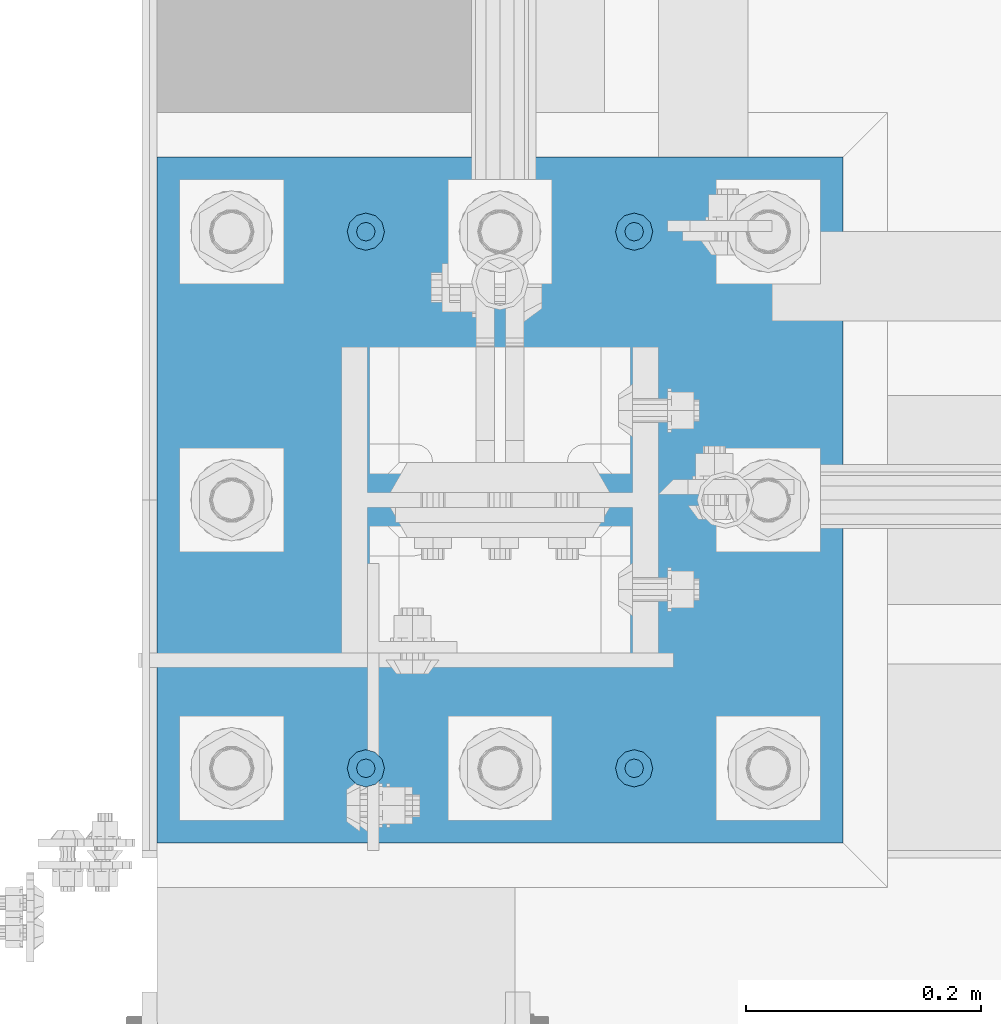
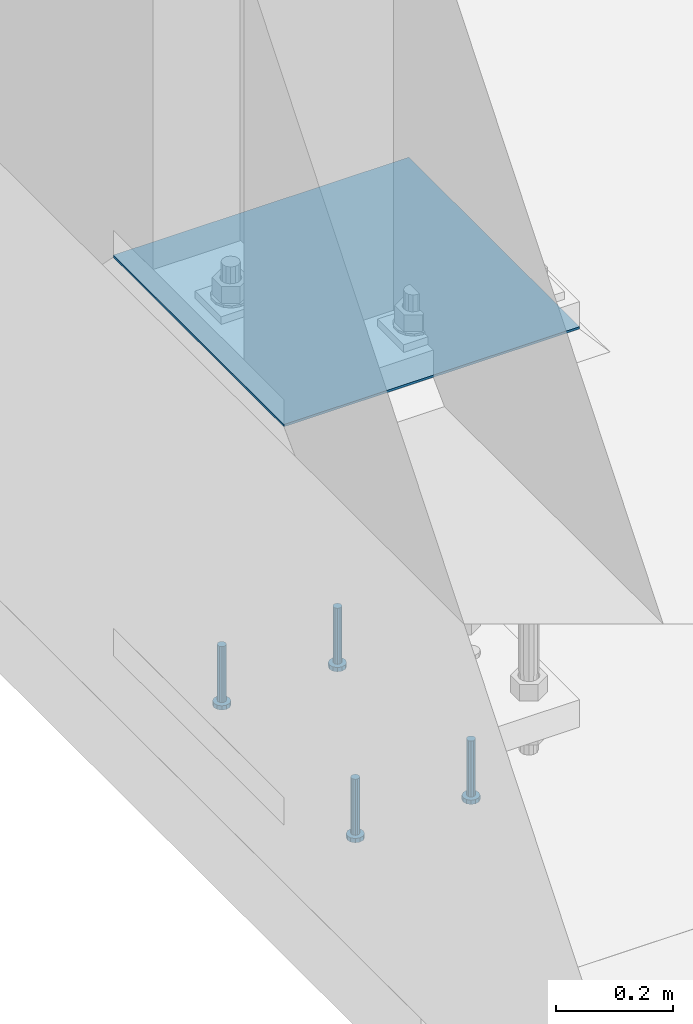
# One storey, part 1124 of 1876: 5 beams, 1 element without a shape of its own.
"""IFC2X3 building model written with IfcOpenShell, lengths in millimetres."""

from ifc_helpers import new_model, si_unit, frame, origin_with_axes, place, context, subcontext, project, spatial, faceted_brep, material, type_object, element, aggregate, save


model = new_model("IFC2X3")

# Units and contexts
model_context = context("Model", 3, precision=1e-05, world=origin_with_axes())
body_context = subcontext(model_context, "Body", "Model", "MODEL_VIEW")
ifc_project = project(units=[si_unit("LENGTHUNIT", "METRE", prefix="MILLI"), si_unit("AREAUNIT", "SQUARE_METRE"), si_unit("VOLUMEUNIT", "CUBIC_METRE"), si_unit("MASSUNIT", "GRAM", prefix="KILO"), si_unit("TIMEUNIT", "SECOND"), si_unit("PLANEANGLEUNIT", "RADIAN"), si_unit("SOLIDANGLEUNIT", "STERADIAN"), si_unit("THERMODYNAMICTEMPERATUREUNIT", "DEGREE_CELSIUS"), si_unit("LUMINOUSINTENSITYUNIT", "LUMEN")], contexts=[model_context])

# Site, building, storey
site_placement = place(None, origin_with_axes())
site = spatial("IfcSite", under=ifc_project, at=site_placement, CompositionType="ELEMENT")
building_placement = place(site_placement, origin_with_axes())
building = spatial("IfcBuilding", under=site, at=building_placement, Name="Undefined", CompositionType="ELEMENT")
storey_placement = place(building_placement, origin_with_axes())
storey = spatial("IfcBuildingStorey", under=building, at=storey_placement, Name="Undefined", CompositionType="ELEMENT", Elevation=0.0)

# Assembly, beams
assembly_placement = place(storey_placement, origin_with_axes())
assembly = element("IfcElementAssembly", 1, at=assembly_placement, inside=storey, Name="TEMPLATE", AssemblyPlace="NOTDEFINED", PredefinedType="RIGID_FRAME")
ifc_material_1 = material(Name="STEEL/A108")
beam_type_1 = type_object("IfcBeamType", Name="5/8-DIA_HEADED ANCHOR STUD", PredefinedType="NOTDEFINED")
beam_1_placement = place(assembly_placement, frame((114.3, -6883.4, -793.75), z_axis=(1.0, 0.0, 0.0), x_axis=(0.0, 0.0, -1.0)))
beam_1 = element("IfcBeam", 2, at=beam_1_placement, type_object=beam_type_1, material=ifc_material_1, Name="HEADED ANCHOR STUD", ObjectType="5/8-DIA_HEADED ANCHOR STUD", context=body_context, shape_type="Brep", body=[
    faceted_brep([(0.0, -7.94000005722046, 0.0), (0.0, -6.86999988555908, -3.97000002861023), (116.84, -6.86999988555908, -3.97000002861023), (116.84, -7.94000005722046, 0.0), (0.0, -3.97000002861023, -6.86999988555908), (116.84, -3.97000002861023, -6.86999988555908), (0.0, 0.0, -7.94000005722046), (116.84, 0.0, -7.94000005722046), (0.0, 3.97000002861023, -6.86999988555908), (116.84, 3.97000002861023, -6.86999988555908), (0.0, 6.86999988555908, -3.97000002861023), (116.84, 6.86999988555908, -3.97000002861023), (0.0, 7.94000005722046, 0.0), (116.84, 7.94000005722046, 0.0), (0.0, 6.86999988555908, 3.97000002861023), (116.84, 6.86999988555908, 3.97000002861023), (0.0, 3.97000002861023, 6.86999988555908), (116.84, 3.97000002861023, 6.86999988555908), (0.0, 0.0, 7.94000005722046), (116.84, 0.0, 7.94000005722046), (0.0, -3.97000002861023, 6.86999988555908), (116.84, -3.97000002861023, 6.86999988555908), (0.0, -6.86999988555908, 3.97000002861023), (116.84, -6.86999988555908, 3.97000002861023), (118.11, -13.75, -7.94000005722046), (118.11, -15.8800001144409, 0.0), (118.11, -7.94000005722046, -13.75), (118.11, 0.0, -15.8800001144409), (118.11, 7.94000005722046, -13.75), (118.11, 13.75, -7.94000005722046), (118.11, 15.8800001144409, 0.0), (118.11, 13.75, 7.94000005722046), (118.11, 7.94000005722046, 13.75), (118.11, 0.0, 15.8800001144409), (118.11, -7.94000005722046, 13.75), (118.11, -13.75, 7.94000005722046), (127.0, -13.75, -7.94000005722046), (127.0, -15.8800001144409, 0.0), (127.0, -7.94000005722046, -13.75), (127.0, 0.0, -15.8800001144409), (127.0, 7.94000005722046, -13.75), (127.0, 13.75, -7.94000005722046), (127.0, 15.8800001144409, 0.0), (127.0, 13.75, 7.94000005722046), (127.0, 7.94000005722046, 13.75), (127.0, 0.0, 15.8800001144409), (127.0, -7.94000005722046, 13.75), (127.0, -13.75, 7.94000005722046)], [[[0, 1, 2, 3]], [[1, 4, 5, 2]], [[4, 6, 7, 5]], [[6, 8, 9, 7]], [[8, 10, 11, 9]], [[10, 12, 13, 11]], [[12, 14, 15, 13]], [[14, 16, 17, 15]], [[16, 18, 19, 17]], [[18, 20, 21, 19]], [[20, 22, 23, 21]], [[22, 0, 3, 23]], [[22, 20, 18, 16, 14, 12, 10, 8, 6, 4, 1, 0]], [[3, 2, 24, 25]], [[2, 5, 26, 24]], [[5, 7, 27, 26]], [[7, 9, 28, 27]], [[9, 11, 29, 28]], [[11, 13, 30, 29]], [[13, 15, 31, 30]], [[15, 17, 32, 31]], [[17, 19, 33, 32]], [[19, 21, 34, 33]], [[21, 23, 35, 34]], [[23, 3, 25, 35]], [[25, 24, 36, 37]], [[24, 26, 38, 36]], [[26, 27, 39, 38]], [[27, 28, 40, 39]], [[28, 29, 41, 40]], [[29, 30, 42, 41]], [[30, 31, 43, 42]], [[31, 32, 44, 43]], [[32, 33, 45, 44]], [[33, 34, 46, 45]], [[34, 35, 47, 46]], [[35, 25, 37, 47]], [[38, 39, 40, 41, 42, 43, 44, 45, 46, 47, 37, 36]]]),
])
beam_2_placement = place(assembly_placement, frame((-114.3, -6883.4, -793.75), z_axis=(1.0, 0.0, 0.0), x_axis=(0.0, 0.0, -1.0)))
beam_2 = element("IfcBeam", 3, at=beam_2_placement, type_object=beam_type_1, material=ifc_material_1, Name="HEADED ANCHOR STUD", ObjectType="5/8-DIA_HEADED ANCHOR STUD", context=body_context, shape_type="Brep", body=[
    faceted_brep([(0.0, -7.94000005722046, 0.0), (0.0, -6.86999988555908, -3.97000002861023), (116.84, -6.86999988555908, -3.97000002861023), (116.84, -7.94000005722046, 0.0), (0.0, -3.97000002861023, -6.86999988555908), (116.84, -3.97000002861023, -6.86999988555908), (0.0, 0.0, -7.94000005722046), (116.84, 0.0, -7.94000005722046), (0.0, 3.97000002861023, -6.86999988555908), (116.84, 3.97000002861023, -6.86999988555908), (0.0, 6.86999988555908, -3.97000002861023), (116.84, 6.86999988555908, -3.97000002861023), (0.0, 7.94000005722046, 0.0), (116.84, 7.94000005722046, 0.0), (0.0, 6.86999988555908, 3.97000002861023), (116.84, 6.86999988555908, 3.97000002861023), (0.0, 3.97000002861023, 6.86999988555908), (116.84, 3.97000002861023, 6.86999988555908), (0.0, 0.0, 7.94000005722046), (116.84, 0.0, 7.94000005722046), (0.0, -3.97000002861023, 6.86999988555908), (116.84, -3.97000002861023, 6.86999988555908), (0.0, -6.86999988555908, 3.97000002861023), (116.84, -6.86999988555908, 3.97000002861023), (118.11, -13.75, -7.94000005722046), (118.11, -15.8800001144409, 0.0), (118.11, -7.94000005722046, -13.75), (118.11, 0.0, -15.8800001144409), (118.11, 7.94000005722046, -13.75), (118.11, 13.75, -7.94000005722046), (118.11, 15.8800001144409, 0.0), (118.11, 13.75, 7.94000005722046), (118.11, 7.94000005722046, 13.75), (118.11, 0.0, 15.8800001144409), (118.11, -7.94000005722046, 13.75), (118.11, -13.75, 7.94000005722046), (127.0, -13.75, -7.94000005722046), (127.0, -15.8800001144409, 0.0), (127.0, -7.94000005722046, -13.75), (127.0, 0.0, -15.8800001144409), (127.0, 7.94000005722046, -13.75), (127.0, 13.75, -7.94000005722046), (127.0, 15.8800001144409, 0.0), (127.0, 13.75, 7.94000005722046), (127.0, 7.94000005722046, 13.75), (127.0, 0.0, 15.8800001144409), (127.0, -7.94000005722046, 13.75), (127.0, -13.75, 7.94000005722046)], [[[0, 1, 2, 3]], [[1, 4, 5, 2]], [[4, 6, 7, 5]], [[6, 8, 9, 7]], [[8, 10, 11, 9]], [[10, 12, 13, 11]], [[12, 14, 15, 13]], [[14, 16, 17, 15]], [[16, 18, 19, 17]], [[18, 20, 21, 19]], [[20, 22, 23, 21]], [[22, 0, 3, 23]], [[22, 20, 18, 16, 14, 12, 10, 8, 6, 4, 1, 0]], [[3, 2, 24, 25]], [[2, 5, 26, 24]], [[5, 7, 27, 26]], [[7, 9, 28, 27]], [[9, 11, 29, 28]], [[11, 13, 30, 29]], [[13, 15, 31, 30]], [[15, 17, 32, 31]], [[17, 19, 33, 32]], [[19, 21, 34, 33]], [[21, 23, 35, 34]], [[23, 3, 25, 35]], [[25, 24, 36, 37]], [[24, 26, 38, 36]], [[26, 27, 39, 38]], [[27, 28, 40, 39]], [[28, 29, 41, 40]], [[29, 30, 42, 41]], [[30, 31, 43, 42]], [[31, 32, 44, 43]], [[32, 33, 45, 44]], [[33, 34, 46, 45]], [[34, 35, 47, 46]], [[35, 25, 37, 47]], [[38, 39, 40, 41, 42, 43, 44, 45, 46, 47, 37, 36]]]),
])
beam_3_placement = place(assembly_placement, frame((114.3, -7340.6, -793.75), z_axis=(1.0, 0.0, 0.0), x_axis=(0.0, 0.0, -1.0)))
beam_3 = element("IfcBeam", 4, at=beam_3_placement, type_object=beam_type_1, material=ifc_material_1, Name="HEADED ANCHOR STUD", ObjectType="5/8-DIA_HEADED ANCHOR STUD", context=body_context, shape_type="Brep", body=[
    faceted_brep([(0.0, -7.94000005722046, 0.0), (0.0, -6.86999988555908, -3.97000002861023), (116.84, -6.86999988555908, -3.97000002861023), (116.84, -7.94000005722046, 0.0), (0.0, -3.97000002861023, -6.86999988555908), (116.84, -3.97000002861023, -6.86999988555908), (0.0, 0.0, -7.94000005722046), (116.84, 0.0, -7.94000005722046), (0.0, 3.97000002861023, -6.86999988555908), (116.84, 3.97000002861023, -6.86999988555908), (0.0, 6.86999988555908, -3.97000002861023), (116.84, 6.86999988555908, -3.97000002861023), (0.0, 7.94000005722046, 0.0), (116.84, 7.94000005722046, 0.0), (0.0, 6.86999988555908, 3.97000002861023), (116.84, 6.86999988555908, 3.97000002861023), (0.0, 3.97000002861023, 6.86999988555908), (116.84, 3.97000002861023, 6.86999988555908), (0.0, 0.0, 7.94000005722046), (116.84, 0.0, 7.94000005722046), (0.0, -3.97000002861023, 6.86999988555908), (116.84, -3.97000002861023, 6.86999988555908), (0.0, -6.86999988555908, 3.97000002861023), (116.84, -6.86999988555908, 3.97000002861023), (118.11, -13.75, -7.94000005722046), (118.11, -15.8800001144409, 0.0), (118.11, -7.94000005722046, -13.75), (118.11, 0.0, -15.8800001144409), (118.11, 7.94000005722046, -13.75), (118.11, 13.75, -7.94000005722046), (118.11, 15.8800001144409, 0.0), (118.11, 13.75, 7.94000005722046), (118.11, 7.94000005722046, 13.75), (118.11, 0.0, 15.8800001144409), (118.11, -7.94000005722046, 13.75), (118.11, -13.75, 7.94000005722046), (127.0, -13.75, -7.94000005722046), (127.0, -15.8800001144409, 0.0), (127.0, -7.94000005722046, -13.75), (127.0, 0.0, -15.8800001144409), (127.0, 7.94000005722046, -13.75), (127.0, 13.75, -7.94000005722046), (127.0, 15.8800001144409, 0.0), (127.0, 13.75, 7.94000005722046), (127.0, 7.94000005722046, 13.75), (127.0, 0.0, 15.8800001144409), (127.0, -7.94000005722046, 13.75), (127.0, -13.75, 7.94000005722046)], [[[0, 1, 2, 3]], [[1, 4, 5, 2]], [[4, 6, 7, 5]], [[6, 8, 9, 7]], [[8, 10, 11, 9]], [[10, 12, 13, 11]], [[12, 14, 15, 13]], [[14, 16, 17, 15]], [[16, 18, 19, 17]], [[18, 20, 21, 19]], [[20, 22, 23, 21]], [[22, 0, 3, 23]], [[22, 20, 18, 16, 14, 12, 10, 8, 6, 4, 1, 0]], [[3, 2, 24, 25]], [[2, 5, 26, 24]], [[5, 7, 27, 26]], [[7, 9, 28, 27]], [[9, 11, 29, 28]], [[11, 13, 30, 29]], [[13, 15, 31, 30]], [[15, 17, 32, 31]], [[17, 19, 33, 32]], [[19, 21, 34, 33]], [[21, 23, 35, 34]], [[23, 3, 25, 35]], [[25, 24, 36, 37]], [[24, 26, 38, 36]], [[26, 27, 39, 38]], [[27, 28, 40, 39]], [[28, 29, 41, 40]], [[29, 30, 42, 41]], [[30, 31, 43, 42]], [[31, 32, 44, 43]], [[32, 33, 45, 44]], [[33, 34, 46, 45]], [[34, 35, 47, 46]], [[35, 25, 37, 47]], [[38, 39, 40, 41, 42, 43, 44, 45, 46, 47, 37, 36]]]),
])
beam_4_placement = place(assembly_placement, frame((-114.3, -7340.6, -793.75), z_axis=(1.0, 0.0, 0.0), x_axis=(0.0, 0.0, -1.0)))
beam_4 = element("IfcBeam", 5, at=beam_4_placement, type_object=beam_type_1, material=ifc_material_1, Name="HEADED ANCHOR STUD", ObjectType="5/8-DIA_HEADED ANCHOR STUD", context=body_context, shape_type="Brep", body=[
    faceted_brep([(0.0, -7.94000005722046, 0.0), (0.0, -6.86999988555908, -3.97000002861023), (116.84, -6.86999988555908, -3.97000002861023), (116.84, -7.94000005722046, 0.0), (0.0, -3.97000002861023, -6.86999988555908), (116.84, -3.97000002861023, -6.86999988555908), (0.0, 0.0, -7.94000005722046), (116.84, 0.0, -7.94000005722046), (0.0, 3.97000002861023, -6.86999988555908), (116.84, 3.97000002861023, -6.86999988555908), (0.0, 6.86999988555908, -3.97000002861023), (116.84, 6.86999988555908, -3.97000002861023), (0.0, 7.94000005722046, 0.0), (116.84, 7.94000005722046, 0.0), (0.0, 6.86999988555908, 3.97000002861023), (116.84, 6.86999988555908, 3.97000002861023), (0.0, 3.97000002861023, 6.86999988555908), (116.84, 3.97000002861023, 6.86999988555908), (0.0, 0.0, 7.94000005722046), (116.84, 0.0, 7.94000005722046), (0.0, -3.97000002861023, 6.86999988555908), (116.84, -3.97000002861023, 6.86999988555908), (0.0, -6.86999988555908, 3.97000002861023), (116.84, -6.86999988555908, 3.97000002861023), (118.11, -13.75, -7.94000005722046), (118.11, -15.8800001144409, 0.0), (118.11, -7.94000005722046, -13.75), (118.11, 0.0, -15.8800001144409), (118.11, 7.94000005722046, -13.75), (118.11, 13.75, -7.94000005722046), (118.11, 15.8800001144409, 0.0), (118.11, 13.75, 7.94000005722046), (118.11, 7.94000005722046, 13.75), (118.11, 0.0, 15.8800001144409), (118.11, -7.94000005722046, 13.75), (118.11, -13.75, 7.94000005722046), (127.0, -13.75, -7.94000005722046), (127.0, -15.8800001144409, 0.0), (127.0, -7.94000005722046, -13.75), (127.0, 0.0, -15.8800001144409), (127.0, 7.94000005722046, -13.75), (127.0, 13.75, -7.94000005722046), (127.0, 15.8800001144409, 0.0), (127.0, 13.75, 7.94000005722046), (127.0, 7.94000005722046, 13.75), (127.0, 0.0, 15.8800001144409), (127.0, -7.94000005722046, 13.75), (127.0, -13.75, 7.94000005722046)], [[[0, 1, 2, 3]], [[1, 4, 5, 2]], [[4, 6, 7, 5]], [[6, 8, 9, 7]], [[8, 10, 11, 9]], [[10, 12, 13, 11]], [[12, 14, 15, 13]], [[14, 16, 17, 15]], [[16, 18, 19, 17]], [[18, 20, 21, 19]], [[20, 22, 23, 21]], [[22, 0, 3, 23]], [[22, 20, 18, 16, 14, 12, 10, 8, 6, 4, 1, 0]], [[3, 2, 24, 25]], [[2, 5, 26, 24]], [[5, 7, 27, 26]], [[7, 9, 28, 27]], [[9, 11, 29, 28]], [[11, 13, 30, 29]], [[13, 15, 31, 30]], [[15, 17, 32, 31]], [[17, 19, 33, 32]], [[19, 21, 34, 33]], [[21, 23, 35, 34]], [[23, 3, 25, 35]], [[25, 24, 36, 37]], [[24, 26, 38, 36]], [[26, 27, 39, 38]], [[27, 28, 40, 39]], [[28, 29, 41, 40]], [[29, 30, 42, 41]], [[30, 31, 43, 42]], [[31, 32, 44, 43]], [[32, 33, 45, 44]], [[33, 34, 46, 45]], [[34, 35, 47, 46]], [[35, 25, 37, 47]], [[38, 39, 40, 41, 42, 43, 44, 45, 46, 47, 37, 36]]]),
])
ifc_material_2 = material(Name="STEEL/A36")
beam_type_2 = type_object("IfcBeamType", PredefinedType="NOTDEFINED")
beam_5_placement = place(assembly_placement, frame((292.1, -7112.0, 40.4814999999999), z_axis=(0.0, -1.0, 0.0), x_axis=(-1.0, 0.0, 0.0)))
beam_5 = element("IfcBeam", 6, at=beam_5_placement, type_object=beam_type_2, material=ifc_material_2, Name="TEMPLATE", context=body_context, shape_type="Brep", body=[
    faceted_brep([(0.0, 2.3815, -292.1), (0.0, 2.3815, 292.1), (584.200000000001, 2.3815, 292.1), (584.200000000001, 2.3815, -292.1), (0.0, -2.3815, 292.1), (584.200000000001, -2.3815, 292.1), (0.0, -2.3815, -292.1), (584.200000000001, -2.3815, -292.1)], [[[0, 1, 2, 3]], [[1, 4, 5, 2]], [[4, 6, 7, 5]], [[6, 0, 3, 7]], [[5, 7, 3, 2]], [[6, 4, 1, 0]]]),
])
aggregate(assembly, [beam_1, beam_2, beam_3, beam_4, beam_5])

save(model, "model.ifc")
